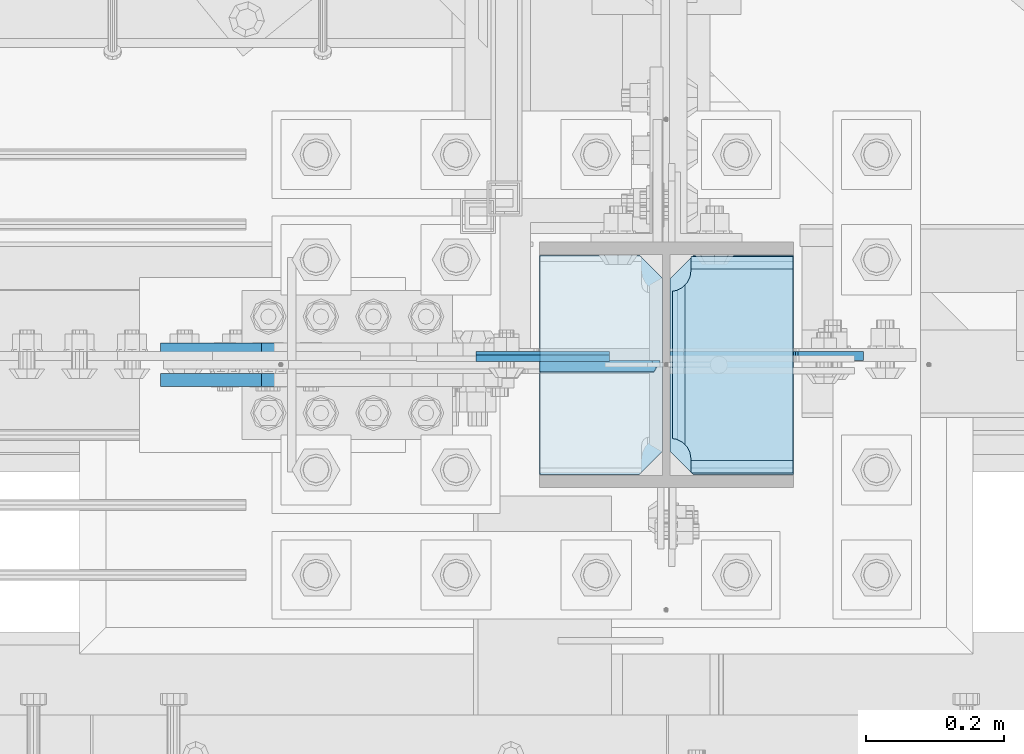
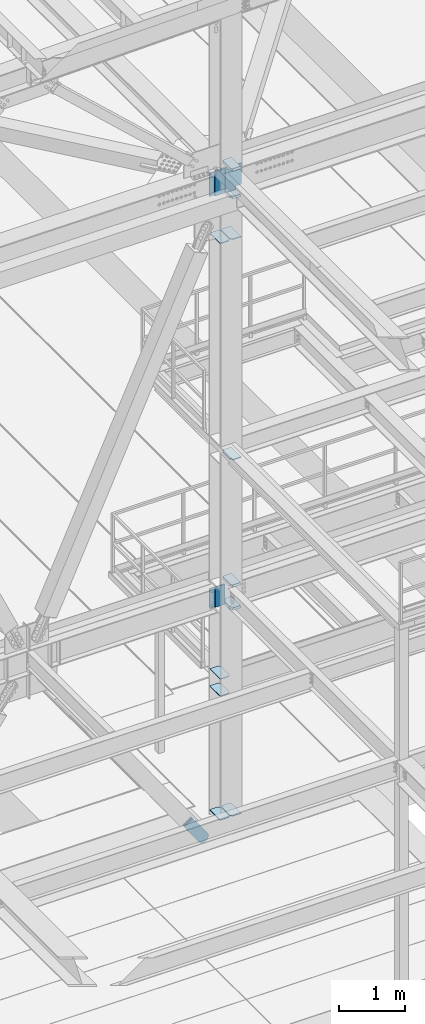
# One storey, part 3134 of 3843: 18 plates, 3 elements without a shape of their own.
"""IFC2X3 building model written with IfcOpenShell, lengths in millimetres."""

from ifc_helpers import new_model, si_unit, frame, origin_with_axes, place, context, subcontext, project, spatial, faceted_brep, material, type_object, element, aggregate, save


model = new_model("IFC2X3")

# Units and contexts
model_context = context("Model", 3, precision=1e-05, world=origin_with_axes())
body_context = subcontext(model_context, "Body", "Model", "MODEL_VIEW")
ifc_project = project(units=[si_unit("LENGTHUNIT", "METRE", prefix="MILLI"), si_unit("AREAUNIT", "SQUARE_METRE"), si_unit("VOLUMEUNIT", "CUBIC_METRE"), si_unit("MASSUNIT", "GRAM", prefix="KILO"), si_unit("TIMEUNIT", "SECOND"), si_unit("PLANEANGLEUNIT", "RADIAN"), si_unit("SOLIDANGLEUNIT", "STERADIAN"), si_unit("THERMODYNAMICTEMPERATUREUNIT", "DEGREE_CELSIUS"), si_unit("LUMINOUSINTENSITYUNIT", "LUMEN")], contexts=[model_context])

# Site, building, storey
site_placement = place(None, origin_with_axes())
site = spatial("IfcSite", under=ifc_project, at=site_placement, CompositionType="ELEMENT")
building_placement = place(site_placement, origin_with_axes())
building = spatial("IfcBuilding", under=site, at=building_placement, Name="Undefined", CompositionType="ELEMENT")
storey_placement = place(building_placement, origin_with_axes())
storey = spatial("IfcBuildingStorey", under=building, at=storey_placement, Name="Undefined", CompositionType="ELEMENT", Elevation=0.0)

# Assembly, plates
assembly_1_placement = place(storey_placement, origin_with_axes())
assembly_1 = element("IfcElementAssembly", 1, at=assembly_1_placement, inside=storey, Name="COLUMN", AssemblyPlace="NOTDEFINED", PredefinedType="RIGID_FRAME")
ifc_material_1 = material(Name="STEEL/A572-50")
plate_type_1 = type_object("IfcPlateType", PredefinedType="NOTDEFINED")
plate_1_placement = place(assembly_1_placement, frame((48991.04375, 25457.15, 32850.1375), z_axis=(0.0, 1.0, 0.0), x_axis=(-1.0, 0.0, 0.0)))
plate_1 = element("IfcPlate", 2, at=plate_1_placement, type_object=plate_type_1, material=ifc_material_1, Name="PLATE", context=body_context, shape_type="Brep", body=[
    faceted_brep([(0.0, -4.76249999999709, 33.3375015258789), (0.0, -4.76249999999709, 284.162498474121), (0.0, 4.76249999999709, 284.162498474121), (0.0, 4.76249999999709, 33.3375015258789), (33.3375015258789, -4.76249999999709, 317.5), (33.3375015258789, 4.76249999999709, 317.5), (177.800003051758, -4.76249999999709, 317.5), (177.800003051758, 4.76249999999709, 317.5), (177.800000000003, -4.76249999999709, -1.45519152283669e-11), (177.800000000003, 4.76249999999709, -1.45519152283669e-11), (33.3375015258789, -4.76249999999709, 0.0), (33.3375015258789, 4.76249999999709, 0.0)], [[[0, 1, 2, 3]], [[1, 4, 5, 2]], [[4, 6, 7, 5]], [[6, 8, 9, 7]], [[8, 10, 11, 9]], [[10, 0, 3, 11]], [[5, 7, 9, 11, 3, 2]], [[10, 8, 6, 4, 1, 0]]]),
])
plate_2_placement = place(assembly_1_placement, frame((48991.04375, 25457.15, 33164.4625), z_axis=(0.0, 1.0, 0.0), x_axis=(-1.0, 0.0, 0.0)))
plate_2 = element("IfcPlate", 3, at=plate_2_placement, type_object=plate_type_1, material=ifc_material_1, Name="PLATE", context=body_context, shape_type="Brep", body=[
    faceted_brep([(0.0, -4.76249999999709, 33.3375015258789), (0.0, -4.76249999999709, 284.162498474121), (0.0, 4.76249999999709, 284.162498474121), (0.0, 4.76249999999709, 33.3375015258789), (33.3375015258789, -4.76249999999709, 317.5), (33.3375015258789, 4.76249999999709, 317.5), (177.800003051758, -4.76249999999709, 317.5), (177.800003051758, 4.76249999999709, 317.5), (177.800000000003, -4.76249999999709, -1.45519152283669e-11), (177.800000000003, 4.76249999999709, -1.45519152283669e-11), (33.3375015258789, -4.76249999999709, 0.0), (33.3375015258789, 4.76249999999709, 0.0)], [[[0, 1, 2, 3]], [[1, 4, 5, 2]], [[4, 6, 7, 5]], [[6, 8, 9, 7]], [[8, 10, 11, 9]], [[10, 0, 3, 11]], [[5, 7, 9, 11, 3, 2]], [[10, 8, 6, 4, 1, 0]]]),
])
plate_type_2 = type_object("IfcPlateType", PredefinedType="NOTDEFINED")
plate_3_placement = place(assembly_1_placement, frame((49002.15625, 25457.15, 30569.0958840152), z_axis=(1.0, 0.0, 0.0), x_axis=(0.0, 1.0, 0.0)))
plate_3 = element("IfcPlate", 4, at=plate_3_placement, type_object=plate_type_2, material=ifc_material_1, Name="CB_COL", context=body_context, shape_type="Brep", body=[
    faceted_brep([(0.0, -6.34999999999854, 33.3375015258789), (0.0, -6.34999999999854, 178.59375), (0.0, 6.34999999999854, 178.59375), (0.0, 6.34999999999854, 33.3375015258789), (317.499999999985, -6.34999999999854, 178.59375), (317.499999999985, 6.34999999999854, 178.59375), (317.499999999985, -6.34999999999854, 33.3375015258789), (317.499999999985, 6.34999999999854, 33.3375015258789), (284.162498474107, -6.34999999999854, 0.0), (284.162498474107, 6.34999999999854, 0.0), (33.3375015258789, -6.34999999999854, 0.0), (33.3375015258789, 6.34999999999854, 0.0)], [[[0, 1, 2, 3]], [[1, 4, 5, 2]], [[4, 6, 7, 5]], [[6, 8, 9, 7]], [[8, 10, 11, 9]], [[10, 0, 3, 11]], [[5, 7, 9, 11, 3, 2]], [[10, 8, 6, 4, 1, 0]]]),
])
plate_4_placement = place(assembly_1_placement, frame((48991.04375, 25457.15, 30569.0958840152), z_axis=(-1.0, 0.0, 0.0), x_axis=(0.0, 1.0, 0.0)))
plate_4 = element("IfcPlate", 5, at=plate_4_placement, type_object=plate_type_2, material=ifc_material_1, Name="CB_COL", context=body_context, shape_type="Brep", body=[
    faceted_brep([(0.0, -6.34999999999854, 33.3375015258789), (0.0, -6.34999999999854, 178.59375), (0.0, 6.34999999999854, 178.59375), (0.0, 6.34999999999854, 33.3375015258789), (317.499999999985, -6.34999999999854, 178.59375), (317.499999999985, 6.34999999999854, 178.59375), (317.499999999985, -6.34999999999854, 33.3375015258789), (317.499999999985, 6.34999999999854, 33.3375015258789), (284.162498474107, -6.34999999999854, 0.0), (284.162498474107, 6.34999999999854, 0.0), (33.3375015258789, -6.34999999999854, 0.0), (33.3375015258789, 6.34999999999854, 0.0)], [[[0, 1, 2, 3]], [[1, 4, 5, 2]], [[4, 6, 7, 5]], [[6, 8, 9, 7]], [[8, 10, 11, 9]], [[10, 0, 3, 11]], [[5, 7, 9, 11, 3, 2]], [[10, 8, 6, 4, 1, 0]]]),
])
plate_5_placement = place(assembly_1_placement, frame((49002.15625, 25457.15, 41184.1782064818), z_axis=(1.0, 0.0, 0.0), x_axis=(0.0, 1.0, 0.0)))
plate_5 = element("IfcPlate", 6, at=plate_5_placement, type_object=plate_type_2, material=ifc_material_1, Name="CB_COL", context=body_context, shape_type="Brep", body=[
    faceted_brep([(0.0, -6.34999999999854, 33.3375015258789), (0.0, -6.34999999999854, 178.59375), (0.0, 6.34999999999854, 178.59375), (0.0, 6.34999999999854, 33.3375015258789), (317.499999999985, -6.34999999999854, 178.59375), (317.499999999985, 6.34999999999854, 178.59375), (317.499999999985, -6.34999999999854, 33.3375015258789), (317.499999999985, 6.34999999999854, 33.3375015258789), (284.162498474107, -6.34999999999854, 0.0), (284.162498474107, 6.34999999999854, 0.0), (33.3375015258789, -6.34999999999854, 0.0), (33.3375015258789, 6.34999999999854, 0.0)], [[[0, 1, 2, 3]], [[1, 4, 5, 2]], [[4, 6, 7, 5]], [[6, 8, 9, 7]], [[8, 10, 11, 9]], [[10, 0, 3, 11]], [[5, 7, 9, 11, 3, 2]], [[10, 8, 6, 4, 1, 0]]]),
])
plate_6_placement = place(assembly_1_placement, frame((48991.04375, 25457.15, 41184.1782064818), z_axis=(-1.0, 0.0, 0.0), x_axis=(0.0, 1.0, 0.0)))
plate_6 = element("IfcPlate", 7, at=plate_6_placement, type_object=plate_type_2, material=ifc_material_1, Name="CB_COL", context=body_context, shape_type="Brep", body=[
    faceted_brep([(0.0, -6.34999999999854, 33.3375015258789), (0.0, -6.34999999999854, 178.59375), (0.0, 6.34999999999854, 178.59375), (0.0, 6.34999999999854, 33.3375015258789), (317.499999999985, -6.34999999999854, 178.59375), (317.499999999985, 6.34999999999854, 178.59375), (317.499999999985, -6.34999999999854, 33.3375015258789), (317.499999999985, 6.34999999999854, 33.3375015258789), (284.162498474107, -6.34999999999854, 0.0), (284.162498474107, 6.34999999999854, 0.0), (33.3375015258789, -6.34999999999854, 0.0), (33.3375015258789, 6.34999999999854, 0.0)], [[[0, 1, 2, 3]], [[1, 4, 5, 2]], [[4, 6, 7, 5]], [[6, 8, 9, 7]], [[8, 10, 11, 9]], [[10, 0, 3, 11]], [[5, 7, 9, 11, 3, 2]], [[10, 8, 6, 4, 1, 0]]]),
])
plate_type_3 = type_object("IfcPlateType", PredefinedType="NOTDEFINED")
plate_7_placement = place(assembly_1_placement, frame((49002.15625, 25776.2375, 41941.75), z_axis=(0.0, -1.0, 0.0), x_axis=(1.0, 0.0, 0.0)))
plate_7 = element("IfcPlate", 8, at=plate_7_placement, type_object=plate_type_3, material=ifc_material_1, Name="PLATE", context=body_context, shape_type="Brep", body=[
    faceted_brep([(17.7290728964945, 9.33242473992141, 272.460514298873), (21.5063709990791, 15.875, 276.23781240145), (21.5063709990791, 15.875, 44.4371753915184), (17.7290728964945, 9.33242473992868, 48.2144734940957), (9.32072521071677, -5.2314900089259, 52.4987406282016), (3.17549995231093, -15.875, 53.4720486914302), (3.17549995231093, -15.875, 267.202939101539), (9.32072521071677, -5.2314900089259, 268.176247164767), (30.1625003814697, 15.875, 299.169629000906), (30.1625003814697, -15.875, 317.500500047678), (177.799999999996, -15.875, 317.500500047678), (177.799999999996, 15.875, 299.169629000906), (177.799999999996, 15.875, 21.5063709990791), (177.799999999996, -15.875, 3.17549995230729), (30.1625003814697, -15.875, 3.17549995230729), (30.1625003814697, 15.875, 21.5063709990791), (9.32072521071314, -15.875, 268.176259371801), (17.7290728964945, -15.875, 272.460526505907), (24.401975401448, -15.875, 279.133429010864), (24.401975401448, 15.875, 279.133429010864), (28.6862425355503, -15.875, 287.541776696642), (28.6862425355503, 15.875, 287.541776696642), (30.1625003814697, -15.875, 296.862501907352), (30.1625003814697, 15.875, 296.862501907352), (30.1625003814697, -15.875, 23.8124980926514), (30.1625003814697, 15.875, 23.8124980926514), (28.6862425355503, -15.875, 33.1332233033609), (28.6862425355503, 15.875, 33.1332233033609), (24.401975401448, -15.875, 41.5415709891386), (24.401975401448, 15.875, 41.5415709891386), (17.7290728964945, -15.875, 48.2144734940957), (9.32072521071677, -15.875, 52.4987406282016)], [[[0, 1, 2, 3, 4, 5, 6, 7]], [[8, 9, 10, 11]], [[12, 13, 14, 15]], [[16, 7, 6]], [[16, 17, 0, 7]], [[17, 18, 19, 1, 0]], [[18, 20, 21, 19]], [[20, 22, 23, 21]], [[23, 22, 9, 8]], [[11, 10, 13, 12]], [[24, 25, 15, 14]], [[24, 26, 27, 25]], [[26, 28, 29, 27]], [[29, 28, 30, 3, 2]], [[30, 31, 4, 3]], [[31, 5, 4]], [[19, 21, 23, 8, 11, 12, 15, 25, 27, 29, 2, 1]], [[31, 30, 28, 26, 24, 14, 13, 10, 9, 22, 20, 18, 17, 16, 6, 5]]]),
])
plate_8_placement = place(assembly_1_placement, frame((49002.15625, 25776.2375, 42452.925), z_axis=(0.0, -1.0, 0.0), x_axis=(1.0, 0.0, 0.0)))
plate_8 = element("IfcPlate", 9, at=plate_8_placement, type_object=plate_type_3, material=ifc_material_1, Name="PLATE", context=body_context, shape_type="Brep", body=[
    faceted_brep([(17.7290728964945, 9.33242473992141, 272.460514298873), (21.5063709990791, 15.875, 276.23781240145), (21.5063709990791, 15.875, 44.4371753915184), (17.7290728964945, 9.33242473992868, 48.2144734940957), (9.32072521071677, -5.2314900089259, 52.4987406282016), (3.17549995231093, -15.875, 53.4720486914302), (3.17549995231093, -15.875, 267.202939101539), (9.32072521071677, -5.2314900089259, 268.176247164767), (30.1625003814697, 15.875, 299.169629000906), (30.1625003814697, -15.875, 317.500500047678), (177.799999999996, -15.875, 317.500500047678), (177.799999999996, 15.875, 299.169629000906), (177.799999999996, 15.875, 21.5063709990791), (177.799999999996, -15.875, 3.17549995230729), (30.1625003814697, -15.875, 3.17549995230729), (30.1625003814697, 15.875, 21.5063709990791), (9.32072521071314, -15.875, 268.176259371801), (17.7290728964945, -15.875, 272.460526505907), (24.401975401448, -15.875, 279.133429010864), (24.401975401448, 15.875, 279.133429010864), (28.6862425355503, -15.875, 287.541776696642), (28.6862425355503, 15.875, 287.541776696642), (30.1625003814697, -15.875, 296.862501907352), (30.1625003814697, 15.875, 296.862501907352), (30.1625003814697, -15.875, 23.8124980926514), (30.1625003814697, 15.875, 23.8124980926514), (28.6862425355503, -15.875, 33.1332233033609), (28.6862425355503, 15.875, 33.1332233033609), (24.401975401448, -15.875, 41.5415709891386), (24.401975401448, 15.875, 41.5415709891386), (17.7290728964945, -15.875, 48.2144734940957), (9.32072521071677, -15.875, 52.4987406282016)], [[[0, 1, 2, 3, 4, 5, 6, 7]], [[8, 9, 10, 11]], [[12, 13, 14, 15]], [[16, 7, 6]], [[16, 17, 0, 7]], [[17, 18, 19, 1, 0]], [[18, 20, 21, 19]], [[20, 22, 23, 21]], [[23, 22, 9, 8]], [[11, 10, 13, 12]], [[24, 25, 15, 14]], [[24, 26, 27, 25]], [[26, 28, 29, 27]], [[29, 28, 30, 3, 2]], [[30, 31, 4, 3]], [[31, 5, 4]], [[19, 21, 23, 8, 11, 12, 15, 25, 27, 29, 2, 1]], [[31, 30, 28, 26, 24, 14, 13, 10, 9, 22, 20, 18, 17, 16, 6, 5]]]),
])
plate_9_placement = place(assembly_1_placement, frame((49002.15625, 25776.2375, 34369.375), z_axis=(0.0, -1.0, 0.0), x_axis=(1.0, 0.0, 0.0)))
plate_9 = element("IfcPlate", 10, at=plate_9_placement, type_object=plate_type_3, material=ifc_material_1, Name="PLATE", context=body_context, shape_type="Brep", body=[
    faceted_brep([(17.7290728964945, 9.33252777098096, 272.4605265059), (21.5063709990791, 15.875, 276.23781240145), (21.5063709990791, 15.875, 44.4371753915184), (17.7290728964945, 9.33252777098824, 48.214473494103), (9.32072521071677, -5.23115762849193, 52.4987406282016), (3.17549995231093, -15.875, 53.4720486914302), (3.17549995231093, -15.875, 267.202939101539), (9.32072521071677, -5.23115762849193, 268.176259371798), (30.1625003814697, 15.875, 299.169629000906), (30.1625003814697, -15.875, 317.500500047678), (177.799999999996, -15.875, 317.500500047678), (177.799999999996, 15.875, 299.169629000906), (177.799999999996, 15.875, 21.5063709990791), (177.799999999996, -15.875, 3.17549995230729), (30.1625003814697, -15.875, 3.17549995230729), (30.1625003814697, 15.875, 21.5063709990791), (9.32072521071314, -15.875, 268.176259371801), (17.7290728964945, -15.875, 272.460526505907), (24.401975401448, -15.875, 279.133429010864), (24.401975401448, 15.875, 279.133429010864), (28.6862425355503, -15.875, 287.541776696642), (28.6862425355503, 15.875, 287.541776696642), (30.1625003814697, -15.875, 296.862501907352), (30.1625003814697, 15.875, 296.862501907352), (30.1625003814697, -15.875, 23.8124980926514), (30.1625003814697, 15.875, 23.8124980926514), (28.6862425355503, -15.875, 33.1332233033609), (28.6862425355503, 15.875, 33.1332233033609), (24.401975401448, -15.875, 41.5415709891386), (24.401975401448, 15.875, 41.5415709891386), (17.7290728964945, -15.875, 48.2144734940957), (9.32072521071677, -15.875, 52.4987406282016)], [[[0, 1, 2, 3, 4, 5, 6, 7]], [[8, 9, 10, 11]], [[12, 13, 14, 15]], [[16, 7, 6]], [[16, 17, 0, 7]], [[17, 18, 19, 1, 0]], [[18, 20, 21, 19]], [[20, 22, 23, 21]], [[23, 22, 9, 8]], [[11, 10, 13, 12]], [[24, 25, 15, 14]], [[24, 26, 27, 25]], [[26, 28, 29, 27]], [[29, 28, 30, 3, 2]], [[30, 31, 4, 3]], [[31, 5, 4]], [[19, 21, 23, 8, 11, 12, 15, 25, 27, 29, 2, 1]], [[31, 30, 28, 26, 24, 14, 13, 10, 9, 22, 20, 18, 17, 16, 6, 5]]]),
])
plate_10_placement = place(assembly_1_placement, frame((49002.15625, 25776.2375, 34794.825), z_axis=(0.0, -1.0, 0.0), x_axis=(1.0, 0.0, 0.0)))
plate_10 = element("IfcPlate", 11, at=plate_10_placement, type_object=plate_type_3, material=ifc_material_1, Name="PLATE", context=body_context, shape_type="Brep", body=[
    faceted_brep([(17.7290728964945, 9.33252777098096, 272.4605265059), (21.5063709990791, 15.875, 276.23781240145), (21.5063709990791, 15.875, 44.4371753915184), (17.7290728964945, 9.33252777098824, 48.214473494103), (9.32072521071677, -5.23115762849193, 52.4987406282016), (3.17549995231093, -15.875, 53.4720486914302), (3.17549995231093, -15.875, 267.202939101539), (9.32072521071677, -5.23115762849193, 268.176259371798), (30.1625003814697, 15.875, 299.169629000906), (30.1625003814697, -15.875, 317.500500047678), (177.799999999996, -15.875, 317.500500047678), (177.799999999996, 15.875, 299.169629000906), (177.799999999996, 15.875, 21.5063709990791), (177.799999999996, -15.875, 3.17549995230729), (30.1625003814697, -15.875, 3.17549995230729), (30.1625003814697, 15.875, 21.5063709990791), (9.32072521071314, -15.875, 268.176259371801), (17.7290728964945, -15.875, 272.460526505907), (24.401975401448, -15.875, 279.133429010864), (24.401975401448, 15.875, 279.133429010864), (28.6862425355503, -15.875, 287.541776696642), (28.6862425355503, 15.875, 287.541776696642), (30.1625003814697, -15.875, 296.862501907352), (30.1625003814697, 15.875, 296.862501907352), (30.1625003814697, -15.875, 23.8124980926514), (30.1625003814697, 15.875, 23.8124980926514), (28.6862425355503, -15.875, 33.1332233033609), (28.6862425355503, 15.875, 33.1332233033609), (24.401975401448, -15.875, 41.5415709891386), (24.401975401448, 15.875, 41.5415709891386), (17.7290728964945, -15.875, 48.2144734940957), (9.32072521071677, -15.875, 52.4987406282016)], [[[0, 1, 2, 3, 4, 5, 6, 7]], [[8, 9, 10, 11]], [[12, 13, 14, 15]], [[16, 7, 6]], [[16, 17, 0, 7]], [[17, 18, 19, 1, 0]], [[18, 20, 21, 19]], [[20, 22, 23, 21]], [[23, 22, 9, 8]], [[11, 10, 13, 12]], [[24, 25, 15, 14]], [[24, 26, 27, 25]], [[26, 28, 29, 27]], [[29, 28, 30, 3, 2]], [[30, 31, 4, 3]], [[31, 5, 4]], [[19, 21, 23, 8, 11, 12, 15, 25, 27, 29, 2, 1]], [[31, 30, 28, 26, 24, 14, 13, 10, 9, 22, 20, 18, 17, 16, 6, 5]]]),
])
plate_type_4 = type_object("IfcPlateType", PredefinedType="NOTDEFINED")
plate_11_placement = place(assembly_1_placement, frame((48720.375, 25625.425, 34767.8375), z_axis=(0.0, 0.0, -1.0), x_axis=(1.0, 0.0, 0.0)))
plate_11 = element("IfcPlate", 12, at=plate_11_placement, type_object=plate_type_4, material=ifc_material_1, Name="PLATE", context=body_context, shape_type="Brep", body=[
    faceted_brep([(0.0, -4.76249999999709, 0.0), (8.90977389644831e-08, -4.76249999999709, 371.474998644393), (8.90977389644831e-08, 4.76249999999709, 371.474998644393), (0.0, 4.76249999999709, 0.0), (193.675000089086, -4.76249999999709, 371.474998644226), (193.675000089086, 4.76249999999709, 371.474998644226), (193.674999999996, -4.76249999999709, 0.0), (193.674999999996, 4.76249999999709, 0.0)], [[[0, 1, 2, 3]], [[1, 4, 5, 2]], [[4, 6, 7, 5]], [[6, 0, 3, 7]], [[5, 7, 3, 2]], [[6, 4, 1, 0]]]),
])
plate_type_5 = type_object("IfcPlateType", PredefinedType="NOTDEFINED")
plate_12_placement = place(assembly_1_placement, frame((48991.04375, 25612.725, 34404.3), z_axis=(-0.707106781186548, 0.0, 0.707106781186548), x_axis=(-0.707106781186548, 0.0, -0.707106781186548)))
plate_12 = element("IfcPlate", 13, at=plate_12_placement, type_object=plate_type_5, material=ifc_material_1, Name="PLATE", context=body_context, shape_type="Brep", body=[
    faceted_brep([(-247.465544341729, 7.9375, 264.917555555565), (13.470384184775, 7.9375, 3.98162703046546), (13.4703841731916, 3.06102272879798, -7.27595761418343e-12), (4.49012799309094, -7.9375, 7.27595761418343e-12), (-251.447171377848, -7.9375, 255.937299369538), (-251.44717137784, 3.06102270769406, 264.917555555572), (-251.447171377826, -7.9375, 273.897811741617), (-136.387639862027, -7.9375, 388.957343257431), (-129.906698250954, 7.9375, 382.47640164634), (131.029230272985, 7.9375, 121.540473118737), (137.510171884061, -7.9375, 115.059531507664), (22.4506403026729, -7.93750001103617, 0.0), (-116.182063423548, -7.9375, 368.751766815243), (-116.182063423548, 7.9375, 368.751766815243), (117.304595441034, -7.9375, 135.265107950687), (117.304595441034, 7.9375, 135.265107950687)], [[[0, 1, 2, 3, 4, 5]], [[6, 7, 8, 0, 5]], [[9, 10, 11, 2, 1]], [[6, 5, 4]], [[12, 13, 8, 7]], [[13, 12, 14, 15]], [[15, 14, 10, 9]], [[8, 13, 15, 9, 1, 0]], [[11, 3, 2]], [[14, 12, 7, 6, 4, 3, 11, 10]]]),
])
plate_type_6 = type_object("IfcPlateType", PredefinedType="NOTDEFINED")
plate_13_placement = place(assembly_1_placement, frame((48720.375, 25628.6, 42413.2375), z_axis=(0.0, 0.0, -1.0), x_axis=(1.0, 0.0, 0.0)))
plate_13 = element("IfcPlate", 14, at=plate_13_placement, type_object=plate_type_6, material=ifc_material_1, Name="PLATE", context=body_context, shape_type="Brep", body=[
    faceted_brep([(0.0, -6.3499999046162, 0.0), (0.0, -6.35000000000582, 431.800000000003), (0.0, 6.35000000000582, 431.800000000003), (7.27595761418343e-12, 6.3499999046162, 0.0), (193.674999999996, -6.35000000000582, 431.800000000003), (193.674999999996, 6.35000000000582, 431.800000000003), (193.674999999996, -6.35000000000582, 0.0), (193.674999999996, 6.35000000000582, 0.0)], [[[0, 1, 2, 3]], [[1, 4, 5, 2]], [[4, 6, 7, 5]], [[6, 0, 3, 7]], [[5, 7, 3, 2]], [[6, 4, 1, 0]]]),
])
plate_type_7 = type_object("IfcPlateType", PredefinedType="NOTDEFINED")
plate_14_placement = place(assembly_1_placement, frame((48991.0437499996, 25614.3125, 41976.675), z_axis=(-0.707106781186548, 0.0, 0.707106781186548), x_axis=(-0.707106781186548, 0.0, -0.707106781186548)))
plate_14 = element("IfcPlate", 15, at=plate_14_placement, type_object=plate_type_7, material=ifc_material_1, Name="PLATE", context=body_context, shape_type="Brep", body=[
    faceted_brep([(-308.082449934242, 7.9375, 325.534107581119), (13.4702073986555, 7.9375, 3.98145024821861), (13.4702065513266, 3.06123817239859, 1.2732925824821e-11), (4.48977442465548, -7.9375, 0.0), (-312.06390018767, -7.9375, 316.553674612336), (-312.06390018767, 3.06123817684784, 325.534106742647), (-312.06390018767, -7.9375, 334.514540549832), (-197.004368672904, -7.9375, 449.574072064608), (-190.523427061838, 7.9375, 443.093130453524), (131.029230272985, 7.9375, 121.540473118737), (137.510171884061, -7.9375, 115.059531507664), (22.4506403026729, -7.93750001103617, 0.0), (-177.921324252063, -7.9375, 430.491027643751), (-177.921324252063, 7.9375, 430.491027643751), (118.427127456042, -7.9375, 134.142575935628), (118.427127456042, 7.9375, 134.142575935628)], [[[0, 1, 2, 3, 4, 5]], [[6, 7, 8, 0, 5]], [[9, 10, 11, 2, 1]], [[6, 5, 4]], [[12, 13, 8, 7]], [[13, 12, 14, 15]], [[15, 14, 10, 9]], [[8, 13, 15, 9, 1, 0]], [[11, 3, 2]], [[14, 12, 7, 6, 4, 3, 11, 10]]]),
])

# Assembly, plate
assembly_2_placement = place(storey_placement, origin_with_axes())
assembly_2 = element("IfcElementAssembly", 16, at=assembly_2_placement, inside=storey, AssemblyPlace="NOTDEFINED", PredefinedType="RIGID_FRAME")
ifc_material_2 = material(Name="STEEL/A36")
plate_type_8 = type_object("IfcPlateType", PredefinedType="NOTDEFINED")
plate_15_placement = place(assembly_2_placement, frame((48409.9345410823, 25638.125, 30664.9590453218), z_axis=(-0.816439959974282, 0.0, -0.5774303349818), x_axis=(0.577430334981802, 0.0, -0.81643995997428)))
plate_15 = element("IfcPlate", 17, at=plate_15_placement, type_object=plate_type_8, material=ifc_material_2, context=body_context, shape_type="Brep", body=[
    faceted_brep([(0.0, -9.52500000000146, 0.0), (7.37782102078199e-09, -9.52499999999418, 179.651701450231), (7.37782102078199e-09, 9.52499999999418, 179.651701450231), (0.0, 9.52500000000146, 0.0), (69.8500000062704, -9.52499999999418, 179.651701450392), (69.8500000062704, 9.52499999999418, 179.651701450392), (171.449999998309, -9.52499999999418, 186.663350727089), (171.449999998309, 9.52499999999418, 186.663350727089), (434.579297655291, -9.52499999999418, 186.663350728457), (434.579297655291, 9.52499999999418, 186.663350728457), (471.637405120986, -9.52499999999418, 179.292034842016), (471.637405120986, 9.52499999999418, 179.292034842016), (503.05375165752, -9.52499999999418, 158.300303204887), (503.05375165752, 9.52499999999418, 158.300303204887), (524.045483294532, -9.52499999999418, 126.883956668345), (524.045483294532, 9.52499999999418, 126.883956668345), (531.416799180792, -9.52499999999418, 89.8258522538526), (531.416799180792, 9.52499999999418, 89.8258522538526), (524.045483293885, -9.52499999999418, 52.7677447886235), (524.045483293885, 9.52499999999418, 52.7677447886235), (503.053751656611, -9.52499999999418, 21.3513982523873), (503.053751656611, 9.52499999999418, 21.3513982523873), (471.637405120178, -9.52499999999418, 0.359666615346214), (471.637405120178, 9.52499999999418, 0.359666615346214), (434.579299181831, -9.52499999999418, -7.01164927131322), (434.579299181831, 9.52499999999418, -7.01164927131322), (171.449999996272, -9.52499999999418, -7.01164927269565), (171.449999996272, 9.52499999999418, -7.01164927269565), (69.8499999979995, -9.52499999999418, -4.00177668780088e-10), (69.8499999979995, 9.52499999999418, -4.00177668780088e-10)], [[[0, 1, 2, 3]], [[1, 4, 5, 2]], [[4, 6, 7, 5]], [[6, 8, 9, 7]], [[8, 10, 11, 9]], [[10, 12, 13, 11]], [[12, 14, 15, 13]], [[14, 16, 17, 15]], [[16, 18, 19, 17]], [[18, 20, 21, 19]], [[20, 22, 23, 21]], [[22, 24, 25, 23]], [[24, 26, 27, 25]], [[26, 28, 29, 27]], [[28, 0, 3, 29]], [[5, 7, 9, 11, 13, 15, 17, 19, 21, 23, 25, 27, 29, 3, 2]], [[28, 26, 24, 22, 20, 18, 16, 14, 12, 10, 8, 6, 4, 1, 0]]]),
])
aggregate(assembly_2, [plate_15])

assembly_3_placement = place(storey_placement, origin_with_axes())
assembly_3 = element("IfcElementAssembly", 18, at=assembly_3_placement, inside=storey, AssemblyPlace="NOTDEFINED", PredefinedType="RIGID_FRAME")
plate_16_placement = place(assembly_3_placement, frame((48409.9345410823, 25593.675, 30664.9590453218), z_axis=(-0.816439959974282, 0.0, -0.5774303349818), x_axis=(0.577430334981802, 0.0, -0.81643995997428)))
plate_16 = element("IfcPlate", 19, at=plate_16_placement, type_object=plate_type_8, material=ifc_material_2, context=body_context, shape_type="Brep", body=[
    faceted_brep([(0.0, -9.52500000000146, 0.0), (7.37782102078199e-09, -9.52499999999418, 179.651701450231), (7.37782102078199e-09, 9.52499999999418, 179.651701450231), (0.0, 9.52500000000146, 0.0), (69.8500000062704, -9.52499999999418, 179.651701450392), (69.8500000062704, 9.52499999999418, 179.651701450392), (171.449999998309, -9.52499999999418, 186.663350727089), (171.449999998309, 9.52499999999418, 186.663350727089), (434.579297655291, -9.52499999999418, 186.663350728457), (434.579297655291, 9.52499999999418, 186.663350728457), (471.637405120986, -9.52499999999418, 179.292034842016), (471.637405120986, 9.52499999999418, 179.292034842016), (503.05375165752, -9.52499999999418, 158.300303204887), (503.05375165752, 9.52499999999418, 158.300303204887), (524.045483294532, -9.52499999999418, 126.883956668345), (524.045483294532, 9.52499999999418, 126.883956668345), (531.416799180792, -9.52499999999418, 89.8258522538526), (531.416799180792, 9.52499999999418, 89.8258522538526), (524.045483293885, -9.52499999999418, 52.7677447886235), (524.045483293885, 9.52499999999418, 52.7677447886235), (503.053751656611, -9.52499999999418, 21.3513982523873), (503.053751656611, 9.52499999999418, 21.3513982523873), (471.637405120178, -9.52499999999418, 0.359666615346214), (471.637405120178, 9.52499999999418, 0.359666615346214), (434.579299181831, -9.52499999999418, -7.01164927131322), (434.579299181831, 9.52499999999418, -7.01164927131322), (171.449999996272, -9.52499999999418, -7.01164927269565), (171.449999996272, 9.52499999999418, -7.01164927269565), (69.8499999979995, -9.52499999999418, -4.00177668780088e-10), (69.8499999979995, 9.52499999999418, -4.00177668780088e-10)], [[[0, 1, 2, 3]], [[1, 4, 5, 2]], [[4, 6, 7, 5]], [[6, 8, 9, 7]], [[8, 10, 11, 9]], [[10, 12, 13, 11]], [[12, 14, 15, 13]], [[14, 16, 17, 15]], [[16, 18, 19, 17]], [[18, 20, 21, 19]], [[20, 22, 23, 21]], [[22, 24, 25, 23]], [[24, 26, 27, 25]], [[26, 28, 29, 27]], [[28, 0, 3, 29]], [[5, 7, 9, 11, 13, 15, 17, 19, 21, 23, 25, 27, 29, 3, 2]], [[28, 26, 24, 22, 20, 18, 16, 14, 12, 10, 8, 6, 4, 1, 0]]]),
])
aggregate(assembly_3, [plate_16])

# Plate
plate_type_9 = type_object("IfcPlateType", PredefinedType="NOTDEFINED")
plate_17_placement = place(assembly_1_placement, frame((49002.15625, 25628.6000000954, 41976.675), z_axis=(0.707106781186548, 0.0, 0.707106781186548), x_axis=(0.707106781186548, 0.0, -0.707106781186548)))
plate_17 = element("IfcPlate", 20, at=plate_17_placement, type_object=plate_type_9, material=ifc_material_1, Name="PLATE", context=body_context, shape_type="Brep", body=[
    faceted_brep([(0.0, -6.3499999046162, 0.0), (-312.063900185356, -6.35000000000582, 312.063900214343), (-312.063900185356, 6.35000000000582, 312.063900214343), (7.27595761418343e-12, 6.3499999046162, 0.0), (-312.063900205583, -6.35000000000582, 339.004668568785), (-312.063900205583, 6.35000000000582, 339.004668568785), (-199.810698692741, -6.35000000000582, 451.257870081594), (-199.810698692741, 6.35000000000582, 451.257870081594), (-190.830442436865, -6.35000000000582, 442.277613825718), (-190.830442436865, 6.35000000000582, 442.277613825718), (-186.710265968726, -6.35000000000582, 439.524599925237), (-186.710265968726, 6.35000000000582, 439.524599925237), (-181.850186450694, -6.35000000000582, 438.557870002638), (-181.850186450694, 6.35000000000582, 438.557870002638), (-176.990106932659, -6.35000000000582, 439.524599925237), (-176.990106932659, 6.35000000000582, 439.524599925237), (-172.869930464509, -6.35000000000582, 442.277613825703), (-172.869930464509, 6.35000000000582, 442.277613825703), (-109.446871474913, -6.35000000000582, 505.700672815292), (-109.446871474913, 6.35000000000582, 505.700672815292), (168.941068276839, -6.35000000000582, 227.312733063431), (168.941068276839, 6.35000000000582, 227.312733063431), (105.518009287243, -6.35000000000582, 163.889674073842), (105.518009287243, 6.35000000000582, 163.889674073842), (102.764995386762, -6.35000000000582, 159.76949760571), (102.764995386762, 6.35000000000582, 159.76949760571), (101.798265464178, -6.35000000000582, 154.909418087671), (101.798265464178, 6.35000000000582, 154.909418087671), (102.764995386762, -6.35000000000582, 150.049338569632), (102.764995386762, 6.35000000000582, 150.049338569632), (105.518009287232, -6.35000000000582, 145.929162101485), (105.518009287232, 6.35000000000582, 145.929162101485), (139.193969875923, -6.35000000000582, 112.25320151278), (139.193969875923, 6.35000000000582, 112.25320151278), (26.9407683632217, -6.34999999999854, 1.30967237055302e-10), (26.9407683632217, 6.34999999999854, 1.30967237055302e-10)], [[[0, 1, 2, 3]], [[1, 4, 5, 2]], [[4, 6, 7, 5]], [[6, 8, 9, 7]], [[8, 10, 11, 9]], [[10, 12, 13, 11]], [[12, 14, 15, 13]], [[14, 16, 17, 15]], [[16, 18, 19, 17]], [[18, 20, 21, 19]], [[20, 22, 23, 21]], [[22, 24, 25, 23]], [[24, 26, 27, 25]], [[26, 28, 29, 27]], [[28, 30, 31, 29]], [[30, 32, 33, 31]], [[32, 34, 35, 33]], [[34, 0, 3, 35]], [[5, 7, 9, 11, 13, 15, 17, 19, 21, 23, 25, 27, 29, 31, 33, 35, 3, 2]], [[34, 32, 30, 28, 26, 24, 22, 20, 18, 16, 14, 12, 10, 8, 6, 4, 1, 0]]]),
])

plate_type_10 = type_object("IfcPlateType", PredefinedType="NOTDEFINED")
plate_18_placement = place(assembly_1_placement, frame((49179.95625, 25455.5625, 37122.1), z_axis=(0.0, 1.0, 0.0), x_axis=(-1.0, 0.0, 0.0)))
plate_18 = element("IfcPlate", 21, at=plate_18_placement, type_object=plate_type_10, material=ifc_material_1, Name="PLATE", context=body_context, shape_type="Brep", body=[
    faceted_brep([(167.292901740009, 6.34999999999854, 51.8942533670051), (167.292901740009, 6.34999999999854, 268.780746632994), (168.479274789279, 4.29514160192775, 268.176259371798), (174.625250048593, -6.34999999999854, 267.202832520103), (174.625250048593, -6.34999999999854, 53.4721674798966), (168.479274789279, 4.29514160192775, 52.4987406282016), (0.0, 6.34999999999854, 310.168151738297), (0.0, -6.34999999999854, 317.500500046885), (147.637499618526, -6.34999999999854, 317.500500046885), (147.637499618526, 6.34999999999854, 310.168151738297), (147.637499618526, 6.34999999999854, 10.5078482601057), (147.637499618526, -6.34999999999854, 3.17549995151785), (0.0, -6.34999999999854, 3.17549995151785), (0.0, 6.34999999999854, 10.5078482601057), (147.637499618526, -6.34999999999854, 296.862501907348), (147.637499618526, 6.34999999999854, 296.862501907348), (149.113757464445, -6.34999999999854, 287.541776696635), (149.113757464445, 6.34999999999854, 287.541776696635), (153.398024598544, -6.34999999999854, 279.133429010853), (153.398024598544, 6.34999999999854, 279.133429010853), (160.070927103501, -6.34999999999854, 272.4605265059), (160.070927103501, 6.34999999999854, 272.4605265059), (168.479274789279, -6.34999999999854, 268.176259371798), (168.479274789279, -6.34999999999854, 52.4987406282016), (160.070927103501, -6.34999999999854, 48.214473494103), (160.070927103501, 6.34999999999854, 48.214473494103), (153.398024598544, -6.34999999999854, 41.5415709891458), (153.398024598544, 6.34999999999854, 41.5415709891458), (149.113757464445, -6.34999999999854, 33.1332233033681), (149.113757464445, 6.34999999999854, 33.1332233033681), (147.637499618526, -6.34999999999854, 23.8124980926514), (147.637499618526, 6.34999999999854, 23.8124980926514)], [[[0, 1, 2, 3, 4, 5]], [[6, 7, 8, 9]], [[10, 11, 12, 13]], [[13, 12, 7, 6]], [[14, 15, 9, 8]], [[14, 16, 17, 15]], [[16, 18, 19, 17]], [[18, 20, 21, 19]], [[21, 20, 22, 2, 1]], [[22, 3, 2]], [[23, 5, 4]], [[23, 24, 25, 0, 5]], [[24, 26, 27, 25]], [[26, 28, 29, 27]], [[28, 30, 31, 29]], [[31, 30, 11, 10]], [[25, 27, 29, 31, 10, 13, 6, 9, 15, 17, 19, 21, 1, 0]], [[11, 30, 28, 26, 24, 23, 4, 3, 22, 20, 18, 16, 14, 8, 7, 12]]]),
])

aggregate(assembly_1, [plate_11, plate_12, plate_13, plate_14, plate_1, plate_2, plate_7, plate_8, plate_9, plate_10, plate_3, plate_4, plate_17, plate_18, plate_5, plate_6])

save(model, "model.ifc")
